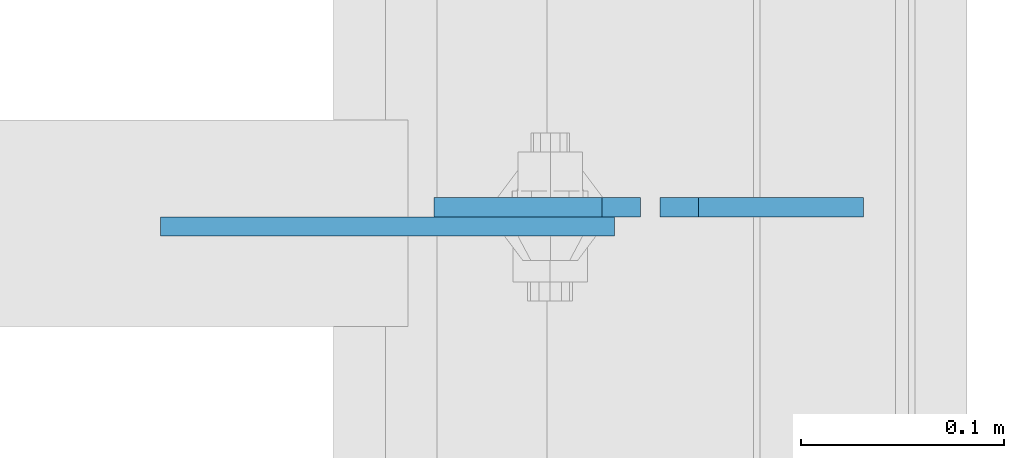
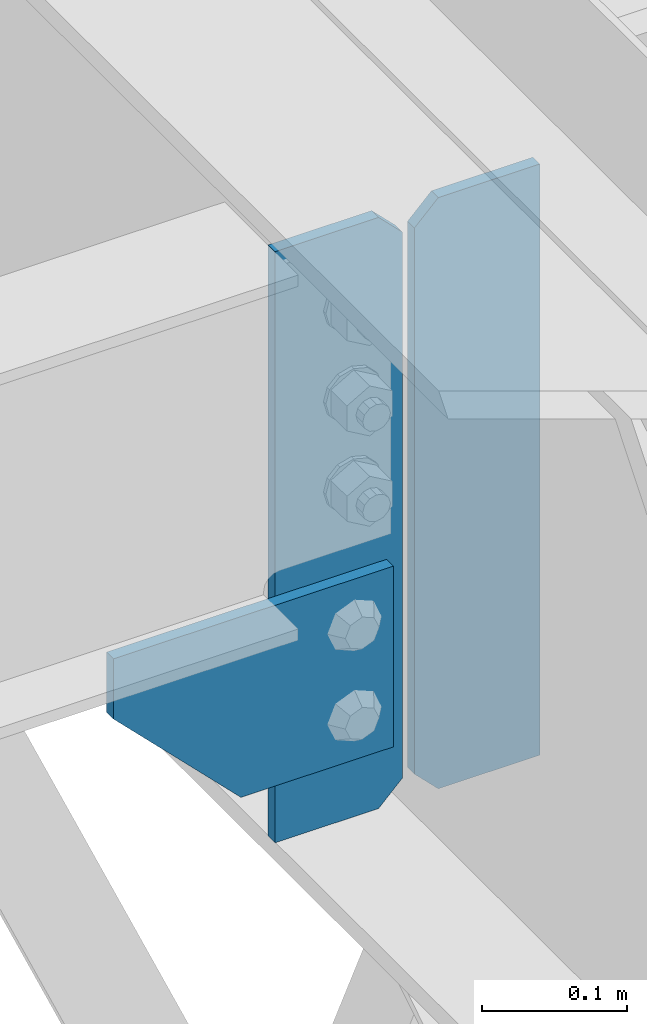
# One storey, part 3024 of 3843: 3 plates, 2 elements without a shape of their own.
"""IFC2X3 building model written with IfcOpenShell, lengths in millimetres."""

from ifc_helpers import new_model, si_unit, frame, origin_with_axes, place, context, subcontext, project, spatial, faceted_brep, material, type_object, element, aggregate, save


model = new_model("IFC2X3")

# Units and contexts
model_context = context("Model", 3, precision=1e-05, world=origin_with_axes())
body_context = subcontext(model_context, "Body", "Model", "MODEL_VIEW")
ifc_project = project(units=[si_unit("LENGTHUNIT", "METRE", prefix="MILLI"), si_unit("AREAUNIT", "SQUARE_METRE"), si_unit("VOLUMEUNIT", "CUBIC_METRE"), si_unit("MASSUNIT", "GRAM", prefix="KILO"), si_unit("TIMEUNIT", "SECOND"), si_unit("PLANEANGLEUNIT", "RADIAN"), si_unit("SOLIDANGLEUNIT", "STERADIAN"), si_unit("THERMODYNAMICTEMPERATUREUNIT", "DEGREE_CELSIUS"), si_unit("LUMINOUSINTENSITYUNIT", "LUMEN")], contexts=[model_context])

# Site, building, storey
site_placement = place(None, origin_with_axes())
site = spatial("IfcSite", under=ifc_project, at=site_placement, CompositionType="ELEMENT")
building_placement = place(site_placement, origin_with_axes())
building = spatial("IfcBuilding", under=site, at=building_placement, Name="Undefined", CompositionType="ELEMENT")
storey_placement = place(building_placement, origin_with_axes())
storey = spatial("IfcBuildingStorey", under=building, at=storey_placement, Name="Undefined", CompositionType="ELEMENT", Elevation=0.0)

# Assembly, plate
assembly_1_placement = place(storey_placement, origin_with_axes())
assembly_1 = element("IfcElementAssembly", 1, at=assembly_1_placement, inside=storey, Name="BEAM", AssemblyPlace="NOTDEFINED", PredefinedType="RIGID_FRAME")
ifc_material = material(Name="STEEL/A572-50")
plate_type_1 = type_object("IfcPlateType", PredefinedType="NOTDEFINED")
plate_1_placement = place(assembly_1_placement, frame((36571.2375, 31110.2379999161, 34294.7625), z_axis=(0.0, 0.0, 1.0), x_axis=(-1.0, 0.0, 0.0)))
plate_1 = element("IfcPlate", 2, at=plate_1_placement, type_object=plate_type_1, material=ifc_material, Name="PLATE", context=body_context, shape_type="Brep", body=[
    faceted_brep([(0.0, -4.76249999999709, 19.0499992370605), (0.0, -4.76250000000073, 479.425000762938), (0.0, 4.76250000000073, 479.425000762938), (0.0, 4.76249999999709, 19.0499992370605), (19.0499992370605, -4.76250000000073, 498.474999999999), (19.0499992370605, 4.76250000000073, 498.474999999999), (101.600000000006, -4.76250000000073, 498.474999999999), (101.600000000006, 4.76250000000073, 498.474999999999), (101.600000000006, -4.76250000000073, 0.0), (101.600000000006, 4.76250000000073, 0.0), (19.0499992370605, -4.76249999999709, 0.0), (19.0499992370605, 4.76249999999709, 0.0)], [[[0, 1, 2, 3]], [[1, 4, 5, 2]], [[4, 6, 7, 5]], [[6, 8, 9, 7]], [[8, 10, 11, 9]], [[10, 0, 3, 11]], [[5, 7, 9, 11, 3, 2]], [[10, 8, 6, 4, 1, 0]]]),
])

assembly_2_placement = place(storey_placement, origin_with_axes())
assembly_2 = element("IfcElementAssembly", 3, at=assembly_2_placement, inside=storey, Name="BEAM", AssemblyPlace="NOTDEFINED", PredefinedType="RIGID_FRAME")
plate_type_2 = type_object("IfcPlateType", PredefinedType="NOTDEFINED")
plate_2_placement = place(assembly_2_placement, frame((36335.3289400347, 31100.7129999161, 34502.725), z_axis=(0.0, 0.0, -1.0), x_axis=(1.0, 0.0, 0.0)))
plate_2 = element("IfcPlate", 4, at=plate_2_placement, type_object=plate_type_2, material=ifc_material, Name="PLATE", context=body_context, shape_type="Brep", body=[
    faceted_brep([(0.0, -4.76249999999709, 0.0), (0.0, -4.76250000000073, 50.7893728663621), (0.0, 4.76250000000073, 50.7893728663621), (0.0, 4.76249999999709, 0.0), (101.599998474121, -4.76250000000073, 152.389371340483), (101.599998474121, 4.76250000000073, 152.389371340483), (223.208559965315, -4.76250000000073, 152.389371340483), (223.208559965315, 4.76250000000073, 152.389371340483), (223.208559965315, -4.76250000000073, 5.82076609134674e-11), (223.208559965315, 4.76250000000073, 5.82076609134674e-11)], [[[0, 1, 2, 3]], [[1, 4, 5, 2]], [[4, 6, 7, 5]], [[6, 8, 9, 7]], [[8, 0, 3, 9]], [[5, 7, 9, 3, 2]], [[8, 6, 4, 1, 0]]]),
])
aggregate(assembly_2, [plate_2])

# Plate
plate_type_3 = type_object("IfcPlateType", PredefinedType="NOTDEFINED")
plate_3_placement = place(assembly_1_placement, frame((36580.7625, 31110.2379999161, 34294.7625), z_axis=(0.0, 0.0, 1.0), x_axis=(1.0, 0.0, 0.0)))
plate_3 = element("IfcPlate", 5, at=plate_3_placement, type_object=plate_type_3, material=ifc_material, Name="PLATE", context=body_context, shape_type="Brep", body=[
    faceted_brep([(0.0, -4.76249999999709, 19.0499992370605), (0.0, -4.76250000000073, 479.425000762938), (0.0, 4.76250000000073, 479.425000762938), (0.0, 4.76249999999709, 19.0499992370605), (19.0499992370605, -4.76250000000073, 498.474999999999), (19.0499992370605, 4.76250000000073, 498.474999999999), (100.012500000004, -4.76250000000073, 498.474999999999), (100.012500000004, 4.76250000000073, 498.474999999999), (100.012500000004, -4.76250000000073, 0.0), (100.012500000004, 4.76250000000073, 0.0), (19.0499992370605, -4.76249999999709, 0.0), (19.0499992370605, 4.76249999999709, 0.0)], [[[0, 1, 2, 3]], [[1, 4, 5, 2]], [[4, 6, 7, 5]], [[6, 8, 9, 7]], [[8, 10, 11, 9]], [[10, 0, 3, 11]], [[5, 7, 9, 11, 3, 2]], [[10, 8, 6, 4, 1, 0]]]),
])

aggregate(assembly_1, [plate_3, plate_1])

save(model, "model.ifc")
